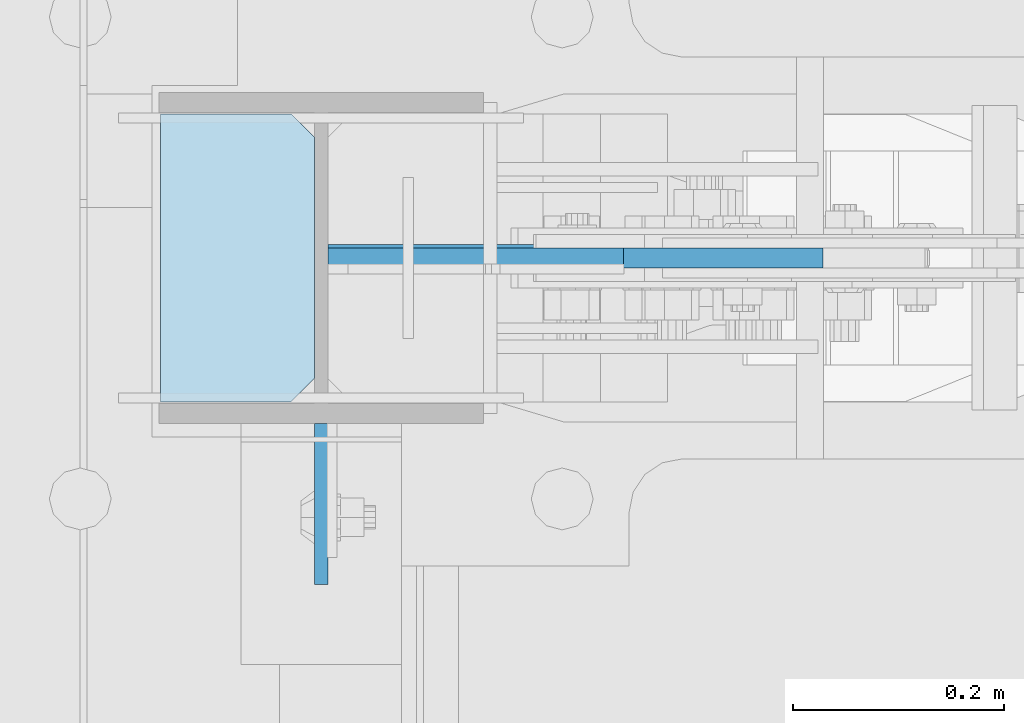
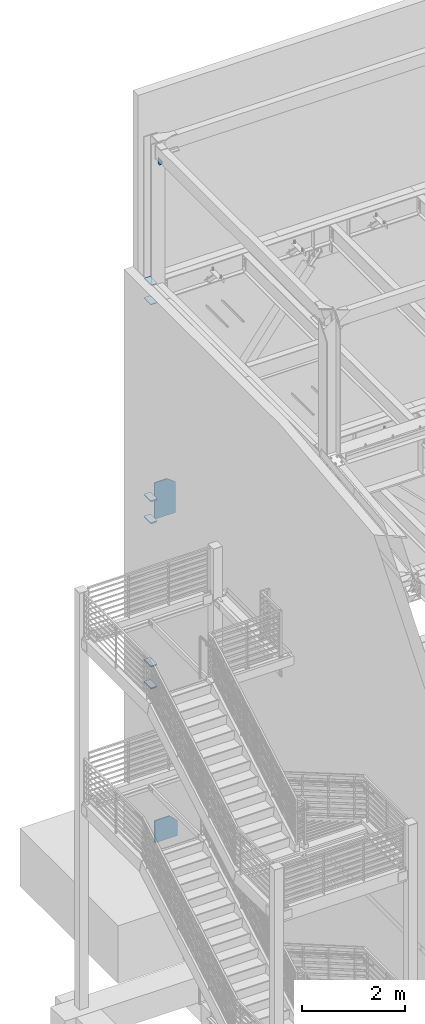
# One storey, part 1065 of 1179: 9 plates, 1 element without a shape of its own.
"""IFC2X3 building model written with IfcOpenShell, lengths in millimetres."""

from ifc_helpers import new_model, si_unit, frame, origin_with_axes, place, context, subcontext, project, spatial, faceted_brep, material, type_object, element, aggregate, save


model = new_model("IFC2X3")

# Units and contexts
model_context = context("Model", 3, precision=1e-05, world=origin_with_axes())
body_context = subcontext(model_context, "Body", "Model", "MODEL_VIEW")
ifc_project = project(units=[si_unit("LENGTHUNIT", "METRE", prefix="MILLI"), si_unit("AREAUNIT", "SQUARE_METRE"), si_unit("VOLUMEUNIT", "CUBIC_METRE"), si_unit("MASSUNIT", "GRAM", prefix="KILO"), si_unit("TIMEUNIT", "SECOND"), si_unit("PLANEANGLEUNIT", "RADIAN"), si_unit("SOLIDANGLEUNIT", "STERADIAN"), si_unit("THERMODYNAMICTEMPERATUREUNIT", "DEGREE_CELSIUS"), si_unit("LUMINOUSINTENSITYUNIT", "LUMEN")], contexts=[model_context])

# Site, building, storey
site_placement = place(None, origin_with_axes())
site = spatial("IfcSite", under=ifc_project, at=site_placement, CompositionType="ELEMENT")
building_placement = place(site_placement, origin_with_axes())
building = spatial("IfcBuilding", under=site, at=building_placement, Name="Undefined", CompositionType="ELEMENT")
storey_placement = place(building_placement, origin_with_axes())
storey = spatial("IfcBuildingStorey", under=building, at=storey_placement, Name="Undefined", CompositionType="ELEMENT", Elevation=0.0)

# Assembly, plates
assembly_placement = place(storey_placement, origin_with_axes())
assembly = element("IfcElementAssembly", 1, at=assembly_placement, inside=storey, Name="COLUMN", AssemblyPlace="NOTDEFINED", PredefinedType="RIGID_FRAME")
ifc_material_1 = material(Name="STEEL/A572-GR.50")
plate_type_1 = type_object("IfcPlateType", PredefinedType="NOTDEFINED")
plate_1_placement = place(assembly_placement, frame((279.4, 41062.275, 7478.7125), z_axis=(0.0, 1.0, 0.0), x_axis=(1.0, 0.0, 0.0)))
plate_1 = element("IfcPlate", 2, at=plate_1_placement, type_object=plate_type_1, material=ifc_material_1, Name="PLATE", context=body_context, shape_type="Brep", body=[
    faceted_brep([(0.0, -14.2875000000004, 0.0), (-5.6843418860808e-14, -14.2875000000004, 273.050000000003), (-5.6843418860808e-14, 14.2875000000004, 273.050000000003), (0.0, 14.2875000000004, 0.0), (123.82499961853, -14.2875000000004, 273.050000000003), (123.82499961853, 14.2875000000004, 273.050000000003), (146.05, -14.2875000000004, 250.824999618533), (146.05, 14.2875000000004, 250.824999618533), (146.05, -14.2875000000004, 22.2250003814697), (146.05, 14.2875000000004, 22.2250003814697), (123.82499961853, -14.2875000000004, 0.0), (123.82499961853, 14.2875000000004, 0.0)], [[[0, 1, 2, 3]], [[1, 4, 5, 2]], [[4, 6, 7, 5]], [[6, 8, 9, 7]], [[8, 10, 11, 9]], [[10, 0, 3, 11]], [[5, 7, 9, 11, 3, 2]], [[10, 8, 6, 4, 1, 0]]]),
])
plate_2_placement = place(assembly_placement, frame((279.4, 41062.275, 7999.4125), z_axis=(0.0, 1.0, 0.0), x_axis=(1.0, 0.0, 0.0)))
plate_2 = element("IfcPlate", 3, at=plate_2_placement, type_object=plate_type_1, material=ifc_material_1, Name="PLATE", context=body_context, shape_type="Brep", body=[
    faceted_brep([(0.0, -14.2875000000004, 0.0), (-5.6843418860808e-14, -14.2875000000004, 273.050000000003), (-5.6843418860808e-14, 14.2875000000004, 273.050000000003), (0.0, 14.2875000000004, 0.0), (123.82499961853, -14.2875000000004, 273.050000000003), (123.82499961853, 14.2875000000004, 273.050000000003), (146.05, -14.2875000000004, 250.824999618533), (146.05, 14.2875000000004, 250.824999618533), (146.05, -14.2875000000004, 22.2250003814697), (146.05, 14.2875000000004, 22.2250003814697), (123.82499961853, -14.2875000000004, 0.0), (123.82499961853, 14.2875000000004, 0.0)], [[[0, 1, 2, 3]], [[1, 4, 5, 2]], [[4, 6, 7, 5]], [[6, 8, 9, 7]], [[8, 10, 11, 9]], [[10, 0, 3, 11]], [[5, 7, 9, 11, 3, 2]], [[10, 8, 6, 4, 1, 0]]]),
])
plate_3_placement = place(assembly_placement, frame((279.4, 41062.275, 3567.11249999999), z_axis=(0.0, 1.0, 0.0), x_axis=(1.0, 0.0, 0.0)))
plate_3 = element("IfcPlate", 4, at=plate_3_placement, type_object=plate_type_1, material=ifc_material_1, Name="PLATE", context=body_context, shape_type="Brep", body=[
    faceted_brep([(0.0, -14.2875000000004, 0.0), (-5.6843418860808e-14, -14.2875000000004, 273.050000000003), (-5.6843418860808e-14, 14.2875000000004, 273.050000000003), (0.0, 14.2875000000004, 0.0), (123.82499961853, -14.2875000000004, 273.050000000003), (123.82499961853, 14.2875000000004, 273.050000000003), (146.05, -14.2875000000004, 250.824999618533), (146.05, 14.2875000000004, 250.824999618533), (146.05, -14.2875000000004, 22.2250003814697), (146.05, 14.2875000000004, 22.2250003814697), (123.82499961853, -14.2875000000004, 0.0), (123.82499961853, 14.2875000000004, 0.0)], [[[0, 1, 2, 3]], [[1, 4, 5, 2]], [[4, 6, 7, 5]], [[6, 8, 9, 7]], [[8, 10, 11, 9]], [[10, 0, 3, 11]], [[5, 7, 9, 11, 3, 2]], [[10, 8, 6, 4, 1, 0]]]),
])
plate_4_placement = place(assembly_placement, frame((279.4, 41062.275, 4087.8125), z_axis=(0.0, 1.0, 0.0), x_axis=(1.0, 0.0, 0.0)))
plate_4 = element("IfcPlate", 5, at=plate_4_placement, type_object=plate_type_1, material=ifc_material_1, Name="PLATE", context=body_context, shape_type="Brep", body=[
    faceted_brep([(0.0, -14.2875000000004, 0.0), (-5.6843418860808e-14, -14.2875000000004, 273.050000000003), (-5.6843418860808e-14, 14.2875000000004, 273.050000000003), (0.0, 14.2875000000004, 0.0), (123.82499961853, -14.2875000000004, 273.050000000003), (123.82499961853, 14.2875000000004, 273.050000000003), (146.05, -14.2875000000004, 250.824999618533), (146.05, 14.2875000000004, 250.824999618533), (146.05, -14.2875000000004, 22.2250003814697), (146.05, 14.2875000000004, 22.2250003814697), (123.82499961853, -14.2875000000004, 0.0), (123.82499961853, 14.2875000000004, 0.0)], [[[0, 1, 2, 3]], [[1, 4, 5, 2]], [[4, 6, 7, 5]], [[6, 8, 9, 7]], [[8, 10, 11, 9]], [[10, 0, 3, 11]], [[5, 7, 9, 11, 3, 2]], [[10, 8, 6, 4, 1, 0]]]),
])
ifc_material_2 = material(Name="STEEL/A36")
plate_type_2 = type_object("IfcPlateType", PredefinedType="NOTDEFINED")
plate_5_placement = place(assembly_placement, frame((431.8, 40889.2375061035, 16109.95), z_axis=(0.0, 1.0, 0.0), x_axis=(0.0, 0.0, -1.0)))
plate_5 = element("IfcPlate", 6, at=plate_5_placement, type_object=plate_type_2, material=ifc_material_2, Name="PLATE", context=body_context, shape_type="Brep", body=[
    faceted_brep([(0.0, -6.34999999999854, 0.0), (0.0, -6.34999999999854, 152.400000000001), (0.0, 6.34999999999854, 152.400000000001), (0.0, 6.34999999999854, 0.0), (152.399993896484, -6.34999999999854, 152.399993896484), (152.399993896484, 6.34999999999854, 152.399993896484), (152.399993896484, -6.34999999999854, 88.6901931762695), (152.399993896484, 6.34999999999854, 88.6901931762695), (63.5, -6.34999999999854, 0.0), (63.5, 6.34999999999854, 0.0)], [[[0, 1, 2, 3]], [[1, 4, 5, 2]], [[4, 6, 7, 5]], [[6, 8, 9, 7]], [[8, 0, 3, 9]], [[5, 7, 9, 3, 2]], [[8, 6, 4, 1, 0]]]),
])
plate_type_3 = type_object("IfcPlateType", PredefinedType="NOTDEFINED")
plate_6_placement = place(assembly_placement, frame((425.45, 41062.275, 12658.725), z_axis=(0.0, 1.0, 0.0), x_axis=(-1.0, 0.0, 0.0)))
plate_6 = element("IfcPlate", 7, at=plate_6_placement, type_object=plate_type_3, material=ifc_material_2, Name="PLATE", context=body_context, shape_type="Brep", body=[
    faceted_brep([(0.0, -6.34999999999854, 22.2250003814697), (0.0, -6.35000000000036, 250.82499961853), (0.0, 6.35000000000036, 250.82499961853), (0.0, 6.34999999999854, 22.2250003814697), (22.2250003814697, -6.35000000000036, 273.05), (22.2250003814697, 6.35000000000036, 273.05), (146.050003051758, -6.35000000000036, 273.049987792969), (146.050003051758, 6.35000000000036, 273.049987792969), (146.050003051758, -6.35000000000036, 0.0), (146.050003051758, 6.35000000000036, 0.0), (22.2250003814697, -6.34999999999854, 0.0), (22.2250003814697, 6.34999999999854, 0.0)], [[[0, 1, 2, 3]], [[1, 4, 5, 2]], [[4, 6, 7, 5]], [[6, 8, 9, 7]], [[8, 10, 11, 9]], [[10, 0, 3, 11]], [[5, 7, 9, 11, 3, 2]], [[10, 8, 6, 4, 1, 0]]]),
])
plate_7_placement = place(assembly_placement, frame((425.45, 41062.275, 13112.75), z_axis=(0.0, 1.0, 0.0), x_axis=(-1.0, 0.0, 0.0)))
plate_7 = element("IfcPlate", 8, at=plate_7_placement, type_object=plate_type_3, material=ifc_material_2, Name="PLATE", context=body_context, shape_type="Brep", body=[
    faceted_brep([(0.0, -6.34999999999854, 22.2250003814697), (0.0, -6.35000000000036, 250.82499961853), (0.0, 6.35000000000036, 250.82499961853), (0.0, 6.34999999999854, 22.2250003814697), (22.2250003814697, -6.35000000000036, 273.05), (22.2250003814697, 6.35000000000036, 273.05), (146.050003051758, -6.35000000000036, 273.049987792969), (146.050003051758, 6.35000000000036, 273.049987792969), (146.050003051758, -6.35000000000036, 0.0), (146.050003051758, 6.35000000000036, 0.0), (22.2250003814697, -6.34999999999854, 0.0), (22.2250003814697, 6.34999999999854, 0.0)], [[[0, 1, 2, 3]], [[1, 4, 5, 2]], [[4, 6, 7, 5]], [[6, 8, 9, 7]], [[8, 10, 11, 9]], [[10, 0, 3, 11]], [[5, 7, 9, 11, 3, 2]], [[10, 8, 6, 4, 1, 0]]]),
])
plate_type_4 = type_object("IfcPlateType", PredefinedType="NOTDEFINED")
plate_8_placement = place(assembly_placement, frame((438.150000000001, 41198.8, 7445.66299953461), z_axis=(0.0, 0.0, 1.0), x_axis=(1.0, 0.0, 0.0)))
plate_8 = element("IfcPlate", 9, at=plate_8_placement, type_object=plate_type_4, material=ifc_material_1, Name="PLATE", context=body_context, shape_type="Brep", body=[
    faceted_brep([(0.0, -9.52499999999964, 0.0), (0.0, -9.52500000000146, 865.768000327812), (0.0, 9.52500000000146, 865.768000327812), (0.0, 9.52499999999964, 0.0), (280.351297035281, -9.52500000000146, 865.768000327812), (280.351297035281, 9.52500000000146, 865.768000327812), (469.70983100647, -9.52500000000146, 721.383578601358), (469.70983100647, 9.52500000000146, 721.383578601358), (469.70983100647, -9.52500000000146, 0.0), (469.70983100647, 9.52500000000146, 0.0)], [[[0, 1, 2, 3]], [[1, 4, 5, 2]], [[4, 6, 7, 5]], [[6, 8, 9, 7]], [[8, 0, 3, 9]], [[5, 7, 9, 3, 2]], [[8, 6, 4, 1, 0]]]),
])
plate_type_5 = type_object("IfcPlateType", PredefinedType="NOTDEFINED")
plate_9_placement = place(assembly_placement, frame((438.15, 41198.8, -215.900033118257), z_axis=(0.0, 0.0, 1.0), x_axis=(1.0, 0.0, 0.0)))
plate_9 = element("IfcPlate", 10, at=plate_9_placement, type_object=plate_type_5, material=ifc_material_1, Name="PLATE", context=body_context, shape_type="Brep", body=[
    faceted_brep([(0.0, -12.7000000000007, 19.0500000000029), (0.0, -12.6999999999971, 524.798143425219), (0.0, 12.6999999999971, 524.798143425219), (0.0, 12.7000000000007, 19.0500000000029), (334.863236503119, -12.6999999999971, 524.798143425219), (334.863236503119, 12.6999999999971, 524.798143425219), (508.01845540265, -12.6999999999971, 356.741723827944), (508.01845540265, 12.6999999999971, 356.741723827944), (508.018455402651, -12.6999999999971, 0.0), (508.018455402651, 12.6999999999971, 0.0), (19.0499992370605, -12.6999999999971, 0.0), (19.0499992370605, 12.6999999999971, 0.0)], [[[0, 1, 2, 3]], [[1, 4, 5, 2]], [[4, 6, 7, 5]], [[6, 8, 9, 7]], [[8, 10, 11, 9]], [[10, 0, 3, 11]], [[5, 7, 9, 11, 3, 2]], [[10, 8, 6, 4, 1, 0]]]),
])
aggregate(assembly, [plate_1, plate_2, plate_5, plate_3, plate_4, plate_8, plate_9, plate_6, plate_7])

save(model, "model.ifc")
